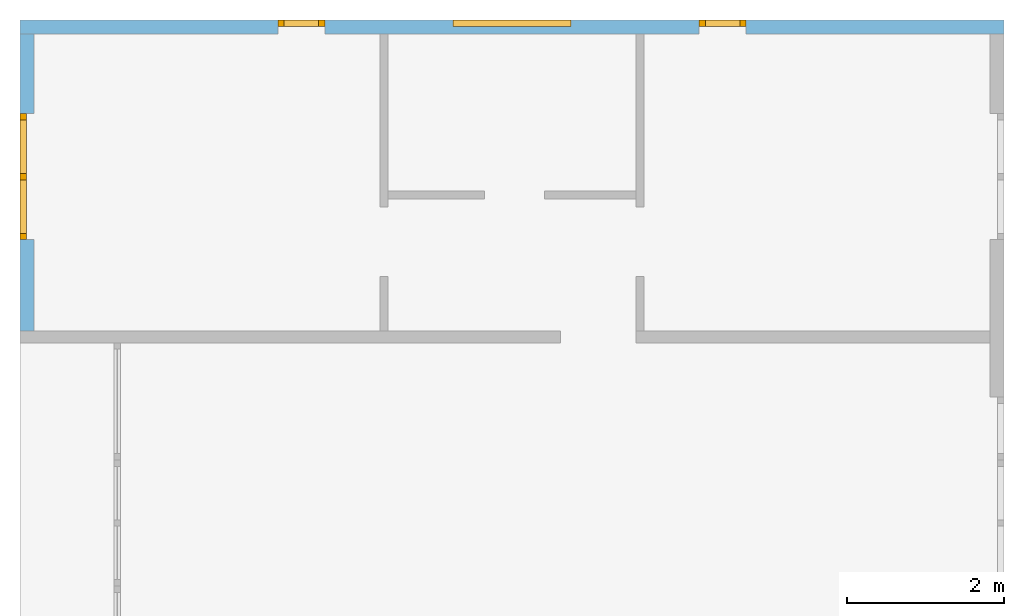
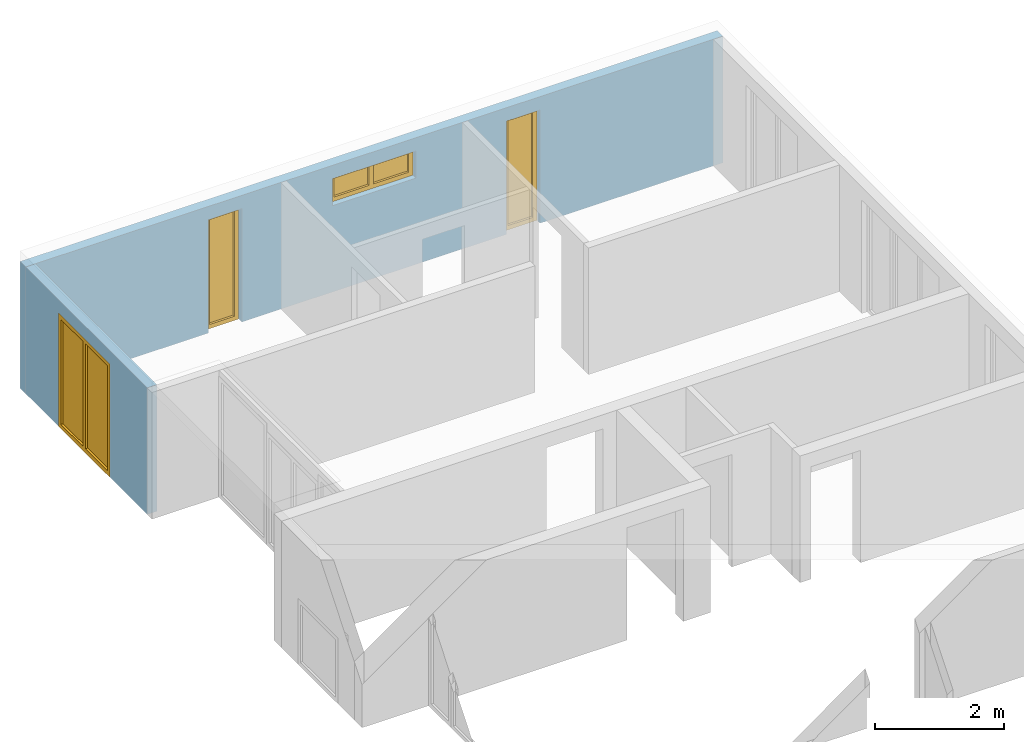
# One storey, part 8 of 8: 4 windows, 4 openings, plus 2 elements that do not belong to this part.
"""IFC2X3 building model written with IfcOpenShell, lengths in millimetres."""

from ifc_helpers import new_model, entity, si_unit, converted_unit, frame, frame_2d, origin, origin_with_axes, place, context, project, spatial, rectangle, extrude, faceted_brep, material, layer, layer_set, layer_usage, element, fill, save


model = new_model("IFC2X3")

# Units and contexts
model_context = context("Model", 3, precision=1e-05, world=origin())
plan_context = context("Plan", 3, precision=1e-05, world=origin())
ifc_project = project(units=[si_unit("LENGTHUNIT", "METRE", prefix="MILLI"), converted_unit("PLANEANGLEUNIT", "DEGREE", entity("IfcPlaneAngleMeasure", 0.0174532925199433), si_unit("PLANEANGLEUNIT", "RADIAN"), dimensions=[0, 0, 0, 0, 0, 0, 0]), si_unit("AREAUNIT", "SQUARE_METRE"), si_unit("VOLUMEUNIT", "CUBIC_METRE")], contexts=[model_context, plan_context])

# Building, storey
building_placement = place(None, origin())
building = spatial("IfcBuilding", under=ifc_project, at=building_placement, CompositionType="ELEMENT")
storey_placement = place(building_placement, frame((0.0, 0.0, 2900.0), z_axis=(0.0, 0.0, 1.0), x_axis=(1.0, 0.0, 0.0)))
storey = spatial("IfcBuildingStorey", under=building, at=storey_placement, Name="OG", CompositionType="ELEMENT", Elevation=2900.0)

# Wall, openings, windows
ifc_material_1 = material(Name="B25")
ifc_layer_1 = layer(ifc_material_1, 175.0)
ifc_layer_set_1 = layer_set([ifc_layer_1])
ifc_layer_usage_1 = layer_usage(ifc_layer_set_1, "AXIS2", "POSITIVE", 0.0)
wall_1_placement = place(storey_placement, frame((33688.3517822139, 9808.4375, 0.0), z_axis=(0.0, 0.0, 1.0), x_axis=(-1.0, 0.0, 0.0)))
wall_1 = element("IfcWallStandardCase", 1, at=wall_1_placement, inside=storey, material=ifc_layer_usage_1, context=model_context, shape_type="SweptSolid", body=[
    extrude(rectangle(XDim=12500.0, YDim=175.0, at=frame_2d((6250.0, 87.5), x_axis=(1.0, 0.0))), origin_with_axes(), (0.0, 0.0, 1.0), 2400.0),
])
opening_1_placement = place(wall_1_placement, frame((3274.9999999553, 0.0, 0.0), z_axis=(0.0, 1.0, 0.0), x_axis=(0.0, 0.0, 1.0)))
opening_1 = element("IfcOpeningElement", 2, at=opening_1_placement, cuts=wall_1, ObjectType="Opening", context=model_context, shape_type="SweptSolid", body=[
    extrude(rectangle(XDim=2150.0, YDim=600.0, at=frame_2d((1075.0, 300.0), x_axis=(1.0, 0.0))), origin_with_axes(), (0.0, 0.0, 1.0), 175.0),
])
opening_2_placement = place(wall_1_placement, frame((5500.00000001148, 0.0, 1635.0), z_axis=(0.0, 1.0, 0.0), x_axis=(0.0, 0.0, 1.0)))
opening_2 = element("IfcOpeningElement", 3, at=opening_2_placement, cuts=wall_1, ObjectType="Opening", context=model_context, shape_type="SweptSolid", body=[
    extrude(rectangle(XDim=515.0, YDim=1500.0, at=frame_2d((257.5, 750.0), x_axis=(1.0, 0.0))), origin_with_axes(), (0.0, 0.0, 1.0), 175.0),
])
opening_3_placement = place(wall_1_placement, frame((8625.0000000447, 0.0, 0.0), z_axis=(0.0, 1.0, 0.0), x_axis=(0.0, 0.0, 1.0)))
opening_3 = element("IfcOpeningElement", 4, at=opening_3_placement, cuts=wall_1, ObjectType="Opening", context=model_context, shape_type="SweptSolid", body=[
    extrude(rectangle(XDim=2150.0, YDim=600.0, at=frame_2d((1075.0, 300.0), x_axis=(1.0, 0.0))), origin_with_axes(), (0.0, 0.0, 1.0), 175.0),
])
ifc_material_2 = material()
window_1_placement = place(opening_1_placement, frame((0.0, 0.0, 0.0), z_axis=(1.0, 0.0, 0.0), x_axis=(0.0, 1.0, 0.0)))
window_1 = element("IfcWindow", 5, at=window_1_placement, inside=storey, material=ifc_material_2, Name="m", OverallHeight=2150.0, OverallWidth=600.0, context=model_context, shape_type="Brep", body=[
    faceted_brep([(80.0, 4.28422852749577e-11, 0.0), (0.0, 4.28619362224936e-11, 0.0), (0.0, 4.28619362224936e-11, 2150.0), (80.0, 4.28422852749577e-11, 2150.0), (0.0, 80.0000000000429, 0.0), (80.0, 80.0000000000428, 0.0), (80.0, 80.0000000000428, 2150.0), (0.0, 80.0000000000429, 2150.0), (0.0, 4.28619362224936e-11, 0.0), (80.0, 4.28422852749577e-11, 0.0), (80.0, 80.0000000000428, 0.0), (0.0, 80.0000000000429, 0.0), (0.0, 4.28619362224936e-11, 2150.0), (0.0, 4.28619362224936e-11, 0.0), (0.0, 80.0000000000429, 0.0), (0.0, 80.0000000000429, 2150.0), (80.0, 4.28422852749577e-11, 2150.0), (0.0, 4.28619362224936e-11, 2150.0), (0.0, 80.0000000000429, 2150.0), (80.0, 80.0000000000428, 2150.0), (80.0, 4.28422852749577e-11, 0.0), (80.0, 4.28422852749577e-11, 2150.0), (80.0, 80.0000000000428, 2150.0), (80.0, 80.0000000000428, 0.0)], [[[0, 1, 2, 3]], [[4, 5, 6, 7]], [[8, 9, 10, 11]], [[12, 13, 14, 15]], [[16, 17, 18, 19]], [[20, 21, 22, 23]]], orient=[[False], [False], [False], [False], [False], [False]]),
    faceted_brep([(520.0, 4.27060609098362e-11, 2150.0), (600.0, 4.26865209846028e-11, 2150.0), (600.0, 4.26865209846028e-11, 0.0), (520.0, 4.27060609098362e-11, 0.0), (600.0, 80.0000000000427, 2150.0), (520.0, 80.0000000000427, 2150.0), (520.0, 80.0000000000427, 0.0), (600.0, 80.0000000000427, 0.0), (600.0, 4.26865209846028e-11, 2150.0), (520.0, 4.27060609098362e-11, 2150.0), (520.0, 80.0000000000427, 2150.0), (600.0, 80.0000000000427, 2150.0), (600.0, 4.26865209846028e-11, 0.0), (600.0, 4.26865209846028e-11, 2150.0), (600.0, 80.0000000000427, 2150.0), (600.0, 80.0000000000427, 0.0), (520.0, 4.27060609098362e-11, 0.0), (600.0, 4.26865209846028e-11, 0.0), (600.0, 80.0000000000427, 0.0), (520.0, 80.0000000000427, 0.0), (520.0, 4.27060609098362e-11, 2150.0), (520.0, 4.27060609098362e-11, 0.0), (520.0, 80.0000000000427, 0.0), (520.0, 80.0000000000427, 2150.0)], [[[0, 1, 2, 3]], [[4, 5, 6, 7]], [[8, 9, 10, 11]], [[12, 13, 14, 15]], [[16, 17, 18, 19]], [[20, 21, 22, 23]]], orient=[[False], [False], [False], [False], [False], [False]]),
    faceted_brep([(520.0, 4.2691850055121e-11, 80.0), (520.0, 4.2691850055121e-11, 0.0), (80.0, 4.27996527108121e-11, 0.0), (80.0, 4.27996527108121e-11, 80.0), (520.0, 80.0000000000427, 0.0), (520.0, 80.0000000000427, 80.0), (80.0, 80.0000000000428, 80.0), (80.0, 80.0000000000428, 0.0), (520.0, 4.2691850055121e-11, 0.0), (520.0, 4.2691850055121e-11, 80.0), (520.0, 80.0000000000427, 80.0), (520.0, 80.0000000000427, 0.0), (80.0, 4.27996527108121e-11, 0.0), (520.0, 4.2691850055121e-11, 0.0), (520.0, 80.0000000000427, 0.0), (80.0, 80.0000000000428, 0.0), (80.0, 4.27996527108121e-11, 80.0), (80.0, 4.27996527108121e-11, 0.0), (80.0, 80.0000000000428, 0.0), (80.0, 80.0000000000428, 80.0), (520.0, 4.2691850055121e-11, 80.0), (80.0, 4.27996527108121e-11, 80.0), (80.0, 80.0000000000428, 80.0), (520.0, 80.0000000000427, 80.0)], [[[0, 1, 2, 3]], [[4, 5, 6, 7]], [[8, 9, 10, 11]], [[12, 13, 14, 15]], [[16, 17, 18, 19]], [[20, 21, 22, 23]]], orient=[[False], [False], [False], [False], [False], [False]]),
    faceted_brep([(80.0, 4.27996527108121e-11, 2070.0), (80.0, 4.27996527108121e-11, 2150.0), (520.0, 4.2691850055121e-11, 2150.0), (520.0, 4.2691850055121e-11, 2070.0), (80.0, 80.0000000000428, 2150.0), (80.0, 80.0000000000428, 2070.0), (520.0, 80.0000000000427, 2070.0), (520.0, 80.0000000000427, 2150.0), (80.0, 4.27996527108121e-11, 2150.0), (80.0, 4.27996527108121e-11, 2070.0), (80.0, 80.0000000000428, 2070.0), (80.0, 80.0000000000428, 2150.0), (520.0, 4.2691850055121e-11, 2150.0), (80.0, 4.27996527108121e-11, 2150.0), (80.0, 80.0000000000428, 2150.0), (520.0, 80.0000000000427, 2150.0), (520.0, 4.2691850055121e-11, 2070.0), (520.0, 4.2691850055121e-11, 2150.0), (520.0, 80.0000000000427, 2150.0), (520.0, 80.0000000000427, 2070.0), (80.0, 4.27996527108121e-11, 2070.0), (520.0, 4.2691850055121e-11, 2070.0), (520.0, 80.0000000000427, 2070.0), (80.0, 80.0000000000428, 2070.0)], [[[0, 1, 2, 3]], [[4, 5, 6, 7]], [[8, 9, 10, 11]], [[12, 13, 14, 15]], [[16, 17, 18, 19]], [[20, 21, 22, 23]]], orient=[[False], [False], [False], [False], [False], [False]]),
    faceted_brep([(520.0, 40.0000000000427, 2070.0), (520.0, 40.0000000000427, 80.0), (80.0, 40.0000000000428, 80.0), (80.0, 40.0000000000428, 2070.0), (520.0, 41.0000000000427, 2070.0), (80.0, 41.0000000000428, 2070.0), (80.0, 41.0000000000428, 80.0), (520.0, 41.0000000000427, 80.0), (520.0, 40.0000000000427, 2070.0), (520.0, 41.0000000000427, 2070.0), (520.0, 41.0000000000427, 80.0), (520.0, 40.0000000000427, 80.0), (520.0, 40.0000000000427, 80.0), (520.0, 41.0000000000427, 80.0), (80.0, 41.0000000000428, 80.0), (80.0, 40.0000000000428, 80.0), (80.0, 40.0000000000428, 80.0), (80.0, 41.0000000000428, 80.0), (80.0, 41.0000000000428, 2070.0), (80.0, 40.0000000000428, 2070.0), (80.0, 40.0000000000428, 2070.0), (80.0, 41.0000000000428, 2070.0), (520.0, 41.0000000000427, 2070.0), (520.0, 40.0000000000427, 2070.0)], [[[0, 1, 2, 3]], [[4, 5, 6, 7]], [[8, 9, 10, 11]], [[12, 13, 14, 15]], [[16, 17, 18, 19]], [[20, 21, 22, 23]]], orient=[[False], [False], [False], [False], [False], [False]]),
])
fill(opening_1, window_1)
ifc_material_3 = material()
window_2_placement = place(opening_2_placement, frame((0.0, 0.0, 0.0), z_axis=(1.0, 0.0, 0.0), x_axis=(0.0, 1.0, 0.0)))
window_2 = element("IfcWindow", 6, at=window_2_placement, inside=storey, material=ifc_material_3, Name="m", OverallHeight=515.0, OverallWidth=1500.0, context=model_context, shape_type="Brep", body=[
    faceted_brep([(1420.0, 4.23280299699513e-11, 0.0), (1420.0, 4.23280299699513e-11, 515.0), (1500.0, 4.23084900447179e-11, 515.0), (1500.0, 4.23084900447179e-11, 0.0), (1500.0, 80.0000000000423, 0.0), (1500.0, 80.0000000000423, 515.0), (1420.0, 80.0000000000423, 515.0), (1420.0, 80.0000000000423, 0.0), (1500.0, 4.23084900447179e-11, 0.0), (1500.0, 80.0000000000423, 0.0), (1420.0, 80.0000000000423, 0.0), (1420.0, 4.23280299699513e-11, 0.0), (1500.0, 4.23084900447179e-11, 515.0), (1500.0, 80.0000000000423, 515.0), (1500.0, 80.0000000000423, 0.0), (1500.0, 4.23084900447179e-11, 0.0), (1420.0, 4.23280299699513e-11, 515.0), (1420.0, 80.0000000000423, 515.0), (1500.0, 80.0000000000423, 515.0), (1500.0, 4.23084900447179e-11, 515.0), (1420.0, 4.23280299699513e-11, 0.0), (1420.0, 80.0000000000423, 0.0), (1420.0, 80.0000000000423, 515.0), (1420.0, 4.23280299699513e-11, 515.0)], [[[0, 1, 2, 3]], [[4, 5, 6, 7]], [[8, 9, 10, 11]], [[12, 13, 14, 15]], [[16, 17, 18, 19]], [[20, 21, 22, 23]]], orient=[[False], [False], [False], [False], [False], [False]]),
    faceted_brep([(80.0, 4.26669810593694e-11, 515.0), (80.0, 4.26669810593694e-11, 0.0), (-1.46952762455441e-16, 4.26865209846028e-11, 0.0), (-1.46952762455441e-16, 4.26865209846028e-11, 515.0), (1.94467488987026e-14, 80.0000000000427, 515.0), (1.94467488987026e-14, 80.0000000000427, 0.0), (80.0, 80.0000000000427, 0.0), (80.0, 80.0000000000427, 515.0), (-1.46952762455441e-16, 4.26865209846028e-11, 515.0), (1.94467488987026e-14, 80.0000000000427, 515.0), (80.0, 80.0000000000427, 515.0), (80.0, 4.26669810593694e-11, 515.0), (-1.46952762455441e-16, 4.26865209846028e-11, 0.0), (1.94467488987026e-14, 80.0000000000427, 0.0), (1.94467488987026e-14, 80.0000000000427, 515.0), (-1.46952762455441e-16, 4.26865209846028e-11, 515.0), (80.0, 4.26669810593694e-11, 0.0), (80.0, 80.0000000000427, 0.0), (1.94467488987026e-14, 80.0000000000427, 0.0), (-1.46952762455441e-16, 4.26865209846028e-11, 0.0), (80.0, 4.26669810593694e-11, 515.0), (80.0, 80.0000000000427, 515.0), (80.0, 80.0000000000427, 0.0), (80.0, 4.26669810593694e-11, 0.0)], [[[0, 1, 2, 3]], [[4, 5, 6, 7]], [[8, 9, 10, 11]], [[12, 13, 14, 15]], [[16, 17, 18, 19]], [[20, 21, 22, 23]]], orient=[[False], [False], [False], [False], [False], [False]]),
    faceted_brep([(1420.0, 4.23706625340969e-11, 435.0), (80.0, 4.26989554824786e-11, 435.0), (80.0, 4.26989554824786e-11, 515.0), (1420.0, 4.23706625340969e-11, 515.0), (1420.0, 80.0000000000424, 515.0), (80.0, 80.0000000000427, 515.0), (80.0, 80.0000000000427, 435.0), (1420.0, 80.0000000000424, 435.0), (1420.0, 4.23706625340969e-11, 515.0), (1420.0, 80.0000000000424, 515.0), (1420.0, 80.0000000000424, 435.0), (1420.0, 4.23706625340969e-11, 435.0), (80.0, 4.26989554824786e-11, 515.0), (80.0, 80.0000000000427, 515.0), (1420.0, 80.0000000000424, 515.0), (1420.0, 4.23706625340969e-11, 515.0), (80.0, 4.26989554824786e-11, 435.0), (80.0, 80.0000000000427, 435.0), (80.0, 80.0000000000427, 515.0), (80.0, 4.26989554824786e-11, 515.0), (1420.0, 4.23706625340969e-11, 435.0), (1420.0, 80.0000000000424, 435.0), (80.0, 80.0000000000427, 435.0), (80.0, 4.26989554824786e-11, 435.0)], [[[0, 1, 2, 3]], [[4, 5, 6, 7]], [[8, 9, 10, 11]], [[12, 13, 14, 15]], [[16, 17, 18, 19]], [[20, 21, 22, 23]]], orient=[[False], [False], [False], [False], [False], [False]]),
    faceted_brep([(80.0, 4.26989554824786e-11, 80.0), (1420.0, 4.23706625340969e-11, 80.0), (1420.0, 4.23706625340969e-11, 0.0), (80.0, 4.26989554824786e-11, 0.0), (80.0, 80.0000000000427, 0.0), (1420.0, 80.0000000000424, 0.0), (1420.0, 80.0000000000424, 80.0), (80.0, 80.0000000000427, 80.0), (80.0, 4.26989554824786e-11, 0.0), (80.0, 80.0000000000427, 0.0), (80.0, 80.0000000000427, 80.0), (80.0, 4.26989554824786e-11, 80.0), (1420.0, 4.23706625340969e-11, 0.0), (1420.0, 80.0000000000424, 0.0), (80.0, 80.0000000000427, 0.0), (80.0, 4.26989554824786e-11, 0.0), (1420.0, 4.23706625340969e-11, 80.0), (1420.0, 80.0000000000424, 80.0), (1420.0, 80.0000000000424, 0.0), (1420.0, 4.23706625340969e-11, 0.0), (80.0, 4.26989554824786e-11, 80.0), (80.0, 80.0000000000427, 80.0), (1420.0, 80.0000000000424, 80.0), (1420.0, 4.23706625340969e-11, 80.0)], [[[0, 1, 2, 3]], [[4, 5, 6, 7]], [[8, 9, 10, 11]], [[12, 13, 14, 15]], [[16, 17, 18, 19]], [[20, 21, 22, 23]]], orient=[[False], [False], [False], [False], [False], [False]]),
    faceted_brep([(710.0, 4.25126600589465e-11, 80.0), (710.0, 4.25126600589465e-11, 435.0), (790.0, 4.24930091114106e-11, 435.0), (790.0, 4.24930091114106e-11, 80.0), (790.0, 80.0000000000425, 80.0), (790.0, 80.0000000000425, 435.0), (710.0, 80.0000000000425, 435.0), (710.0, 80.0000000000425, 80.0), (790.0, 4.24930091114106e-11, 80.0), (790.0, 80.0000000000425, 80.0), (710.0, 80.0000000000425, 80.0), (710.0, 4.25126600589465e-11, 80.0), (790.0, 4.24930091114106e-11, 435.0), (790.0, 80.0000000000425, 435.0), (790.0, 80.0000000000425, 80.0), (790.0, 4.24930091114106e-11, 80.0), (710.0, 4.25126600589465e-11, 435.0), (710.0, 80.0000000000425, 435.0), (790.0, 80.0000000000425, 435.0), (790.0, 4.24930091114106e-11, 435.0), (710.0, 4.25126600589465e-11, 80.0), (710.0, 80.0000000000425, 80.0), (710.0, 80.0000000000425, 435.0), (710.0, 4.25126600589465e-11, 435.0)], [[[0, 1, 2, 3]], [[4, 5, 6, 7]], [[8, 9, 10, 11]], [[12, 13, 14, 15]], [[16, 17, 18, 19]], [[20, 21, 22, 23]]], orient=[[False], [False], [False], [False], [False], [False]]),
    faceted_brep([(80.0, 40.0000000000427, 435.0), (710.0, 40.0000000000425, 435.0), (710.0, 40.0000000000425, 80.0), (80.0, 40.0000000000427, 80.0), (80.0, 41.0000000000427, 435.0), (80.0, 41.0000000000427, 80.0), (710.0, 41.0000000000425, 80.0), (710.0, 41.0000000000425, 435.0), (80.0, 40.0000000000427, 435.0), (80.0, 41.0000000000427, 435.0), (710.0, 41.0000000000425, 435.0), (710.0, 40.0000000000425, 435.0), (710.0, 40.0000000000425, 435.0), (710.0, 41.0000000000425, 435.0), (710.0, 41.0000000000425, 80.0), (710.0, 40.0000000000425, 80.0), (710.0, 40.0000000000425, 80.0), (710.0, 41.0000000000425, 80.0), (80.0, 41.0000000000427, 80.0), (80.0, 40.0000000000427, 80.0), (80.0, 40.0000000000427, 80.0), (80.0, 41.0000000000427, 80.0), (80.0, 41.0000000000427, 435.0), (80.0, 40.0000000000427, 435.0)], [[[0, 1, 2, 3]], [[4, 5, 6, 7]], [[8, 9, 10, 11]], [[12, 13, 14, 15]], [[16, 17, 18, 19]], [[20, 21, 22, 23]]], orient=[[False], [False], [False], [False], [False], [False]]),
    faceted_brep([(1420.0, 40.0000000000424, 80.0), (790.0, 40.0000000000425, 80.0), (790.0, 40.0000000000425, 435.0), (1420.0, 40.0000000000424, 435.0), (1420.0, 41.0000000000424, 80.0), (1420.0, 41.0000000000424, 435.0), (790.0, 41.0000000000425, 435.0), (790.0, 41.0000000000425, 80.0), (1420.0, 40.0000000000424, 80.0), (1420.0, 41.0000000000424, 80.0), (790.0, 41.0000000000425, 80.0), (790.0, 40.0000000000425, 80.0), (790.0, 40.0000000000425, 80.0), (790.0, 41.0000000000425, 80.0), (790.0, 41.0000000000425, 435.0), (790.0, 40.0000000000425, 435.0), (790.0, 40.0000000000425, 435.0), (790.0, 41.0000000000425, 435.0), (1420.0, 41.0000000000424, 435.0), (1420.0, 40.0000000000424, 435.0), (1420.0, 40.0000000000424, 435.0), (1420.0, 41.0000000000424, 435.0), (1420.0, 41.0000000000424, 80.0), (1420.0, 40.0000000000424, 80.0)], [[[0, 1, 2, 3]], [[4, 5, 6, 7]], [[8, 9, 10, 11]], [[12, 13, 14, 15]], [[16, 17, 18, 19]], [[20, 21, 22, 23]]], orient=[[False], [False], [False], [False], [False], [False]]),
])
fill(opening_2, window_2)
ifc_material_4 = material()
window_3_placement = place(opening_3_placement, frame((0.0, 0.0, 0.0), z_axis=(1.0, 0.0, 0.0), x_axis=(0.0, 1.0, 0.0)))
window_3 = element("IfcWindow", 7, at=window_3_placement, inside=storey, material=ifc_material_4, Name="m", OverallHeight=2150.0, OverallWidth=600.0, context=model_context, shape_type="Brep", body=[
    faceted_brep([(80.0, 4.28422852749577e-11, 0.0), (0.0, 4.28619362224936e-11, 0.0), (0.0, 4.28619362224936e-11, 2150.0), (80.0, 4.28422852749577e-11, 2150.0), (0.0, 80.0000000000429, 0.0), (80.0, 80.0000000000428, 0.0), (80.0, 80.0000000000428, 2150.0), (0.0, 80.0000000000429, 2150.0), (0.0, 4.28619362224936e-11, 0.0), (80.0, 4.28422852749577e-11, 0.0), (80.0, 80.0000000000428, 0.0), (0.0, 80.0000000000429, 0.0), (0.0, 4.28619362224936e-11, 2150.0), (0.0, 4.28619362224936e-11, 0.0), (0.0, 80.0000000000429, 0.0), (0.0, 80.0000000000429, 2150.0), (80.0, 4.28422852749577e-11, 2150.0), (0.0, 4.28619362224936e-11, 2150.0), (0.0, 80.0000000000429, 2150.0), (80.0, 80.0000000000428, 2150.0), (80.0, 4.28422852749577e-11, 0.0), (80.0, 4.28422852749577e-11, 2150.0), (80.0, 80.0000000000428, 2150.0), (80.0, 80.0000000000428, 0.0)], [[[0, 1, 2, 3]], [[4, 5, 6, 7]], [[8, 9, 10, 11]], [[12, 13, 14, 15]], [[16, 17, 18, 19]], [[20, 21, 22, 23]]], orient=[[False], [False], [False], [False], [False], [False]]),
    faceted_brep([(520.0, 4.27060609098362e-11, 2150.0), (600.0, 4.26865209846028e-11, 2150.0), (600.0, 4.26865209846028e-11, 0.0), (520.0, 4.27060609098362e-11, 0.0), (600.0, 80.0000000000427, 2150.0), (520.0, 80.0000000000427, 2150.0), (520.0, 80.0000000000427, 0.0), (600.0, 80.0000000000427, 0.0), (600.0, 4.26865209846028e-11, 2150.0), (520.0, 4.27060609098362e-11, 2150.0), (520.0, 80.0000000000427, 2150.0), (600.0, 80.0000000000427, 2150.0), (600.0, 4.26865209846028e-11, 0.0), (600.0, 4.26865209846028e-11, 2150.0), (600.0, 80.0000000000427, 2150.0), (600.0, 80.0000000000427, 0.0), (520.0, 4.27060609098362e-11, 0.0), (600.0, 4.26865209846028e-11, 0.0), (600.0, 80.0000000000427, 0.0), (520.0, 80.0000000000427, 0.0), (520.0, 4.27060609098362e-11, 2150.0), (520.0, 4.27060609098362e-11, 0.0), (520.0, 80.0000000000427, 0.0), (520.0, 80.0000000000427, 2150.0)], [[[0, 1, 2, 3]], [[4, 5, 6, 7]], [[8, 9, 10, 11]], [[12, 13, 14, 15]], [[16, 17, 18, 19]], [[20, 21, 22, 23]]], orient=[[False], [False], [False], [False], [False], [False]]),
    faceted_brep([(520.0, 4.2691850055121e-11, 80.0), (520.0, 4.2691850055121e-11, 0.0), (80.0, 4.27996527108121e-11, 0.0), (80.0, 4.27996527108121e-11, 80.0), (520.0, 80.0000000000427, 0.0), (520.0, 80.0000000000427, 80.0), (80.0, 80.0000000000428, 80.0), (80.0, 80.0000000000428, 0.0), (520.0, 4.2691850055121e-11, 0.0), (520.0, 4.2691850055121e-11, 80.0), (520.0, 80.0000000000427, 80.0), (520.0, 80.0000000000427, 0.0), (80.0, 4.27996527108121e-11, 0.0), (520.0, 4.2691850055121e-11, 0.0), (520.0, 80.0000000000427, 0.0), (80.0, 80.0000000000428, 0.0), (80.0, 4.27996527108121e-11, 80.0), (80.0, 4.27996527108121e-11, 0.0), (80.0, 80.0000000000428, 0.0), (80.0, 80.0000000000428, 80.0), (520.0, 4.2691850055121e-11, 80.0), (80.0, 4.27996527108121e-11, 80.0), (80.0, 80.0000000000428, 80.0), (520.0, 80.0000000000427, 80.0)], [[[0, 1, 2, 3]], [[4, 5, 6, 7]], [[8, 9, 10, 11]], [[12, 13, 14, 15]], [[16, 17, 18, 19]], [[20, 21, 22, 23]]], orient=[[False], [False], [False], [False], [False], [False]]),
    faceted_brep([(80.0, 4.27996527108121e-11, 2070.0), (80.0, 4.27996527108121e-11, 2150.0), (520.0, 4.2691850055121e-11, 2150.0), (520.0, 4.2691850055121e-11, 2070.0), (80.0, 80.0000000000428, 2150.0), (80.0, 80.0000000000428, 2070.0), (520.0, 80.0000000000427, 2070.0), (520.0, 80.0000000000427, 2150.0), (80.0, 4.27996527108121e-11, 2150.0), (80.0, 4.27996527108121e-11, 2070.0), (80.0, 80.0000000000428, 2070.0), (80.0, 80.0000000000428, 2150.0), (520.0, 4.2691850055121e-11, 2150.0), (80.0, 4.27996527108121e-11, 2150.0), (80.0, 80.0000000000428, 2150.0), (520.0, 80.0000000000427, 2150.0), (520.0, 4.2691850055121e-11, 2070.0), (520.0, 4.2691850055121e-11, 2150.0), (520.0, 80.0000000000427, 2150.0), (520.0, 80.0000000000427, 2070.0), (80.0, 4.27996527108121e-11, 2070.0), (520.0, 4.2691850055121e-11, 2070.0), (520.0, 80.0000000000427, 2070.0), (80.0, 80.0000000000428, 2070.0)], [[[0, 1, 2, 3]], [[4, 5, 6, 7]], [[8, 9, 10, 11]], [[12, 13, 14, 15]], [[16, 17, 18, 19]], [[20, 21, 22, 23]]], orient=[[False], [False], [False], [False], [False], [False]]),
    faceted_brep([(520.0, 40.0000000000427, 2070.0), (520.0, 40.0000000000427, 80.0), (80.0, 40.0000000000428, 80.0), (80.0, 40.0000000000428, 2070.0), (520.0, 41.0000000000427, 2070.0), (80.0, 41.0000000000428, 2070.0), (80.0, 41.0000000000428, 80.0), (520.0, 41.0000000000427, 80.0), (520.0, 40.0000000000427, 2070.0), (520.0, 41.0000000000427, 2070.0), (520.0, 41.0000000000427, 80.0), (520.0, 40.0000000000427, 80.0), (520.0, 40.0000000000427, 80.0), (520.0, 41.0000000000427, 80.0), (80.0, 41.0000000000428, 80.0), (80.0, 40.0000000000428, 80.0), (80.0, 40.0000000000428, 80.0), (80.0, 41.0000000000428, 80.0), (80.0, 41.0000000000428, 2070.0), (80.0, 40.0000000000428, 2070.0), (80.0, 40.0000000000428, 2070.0), (80.0, 41.0000000000428, 2070.0), (520.0, 41.0000000000427, 2070.0), (520.0, 40.0000000000427, 2070.0)], [[[0, 1, 2, 3]], [[4, 5, 6, 7]], [[8, 9, 10, 11]], [[12, 13, 14, 15]], [[16, 17, 18, 19]], [[20, 21, 22, 23]]], orient=[[False], [False], [False], [False], [False], [False]]),
])
fill(opening_3, window_3)

# Wall, opening, window
ifc_material_5 = material(Name="B25")
ifc_layer_2 = layer(ifc_material_5, 175.0)
ifc_layer_set_2 = layer_set([ifc_layer_2])
ifc_layer_usage_2 = layer_usage(ifc_layer_set_2, "AXIS2", "POSITIVE", 0.0)
wall_2_placement = place(storey_placement, frame((21188.3517822139, 9633.4375, 0.0), z_axis=(0.0, 0.0, 1.0), x_axis=(0.0, -1.0, 0.0)))
wall_2 = element("IfcWallStandardCase", 8, at=wall_2_placement, inside=storey, material=ifc_layer_usage_2, context=model_context, shape_type="SweptSolid", body=[
    extrude(rectangle(XDim=3775.0, YDim=175.0, at=frame_2d((1887.5, 87.5), x_axis=(1.0, 0.0))), origin_with_axes(), (0.0, 0.0, 1.0), 2400.0),
])
opening_4_placement = place(wall_2_placement, frame((1015.0, 0.0, 0.0), z_axis=(0.0, 1.0, 0.0), x_axis=(0.0, 0.0, 1.0)))
opening_4 = element("IfcOpeningElement", 9, at=opening_4_placement, cuts=wall_2, ObjectType="Opening", context=model_context, shape_type="SweptSolid", body=[
    extrude(rectangle(XDim=2150.0, YDim=1600.0, at=frame_2d((1075.0, 800.0), x_axis=(1.0, 0.0))), origin_with_axes(), (0.0, 0.0, 1.0), 175.0),
])
ifc_material_6 = material()
window_4_placement = place(opening_4_placement, frame((0.0, 0.0, 0.0), z_axis=(1.0, 0.0, 0.0), x_axis=(0.0, 1.0, 0.0)))
window_4 = element("IfcWindow", 10, at=window_4_placement, inside=storey, material=ifc_material_6, Name="m", OverallHeight=2150.0, OverallWidth=1600.0, context=model_context, shape_type="Brep", body=[
    faceted_brep([(80.0000000000009, 4.37465619285149e-11, 0.0), (9.09494701772928e-13, 4.37514469098232e-11, 0.0), (9.09494701772928e-13, 4.37514469098232e-11, 2150.0), (80.0000000000009, 4.37465619285149e-11, 2150.0), (9.09494701772928e-13, 80.0000000000437, 0.0), (80.0000000000009, 80.0000000000437, 0.0), (80.0000000000009, 80.0000000000437, 2150.0), (9.09494701772928e-13, 80.0000000000437, 2150.0), (9.09494701772928e-13, 4.37514469098232e-11, 0.0), (80.0000000000009, 4.37465619285149e-11, 0.0), (80.0000000000009, 80.0000000000437, 0.0), (9.09494701772928e-13, 80.0000000000437, 0.0), (9.09494701772928e-13, 4.37514469098232e-11, 2150.0), (9.09494701772928e-13, 4.37514469098232e-11, 0.0), (9.09494701772928e-13, 80.0000000000437, 0.0), (9.09494701772928e-13, 80.0000000000437, 2150.0), (80.0000000000009, 4.37465619285149e-11, 2150.0), (9.09494701772928e-13, 4.37514469098232e-11, 2150.0), (9.09494701772928e-13, 80.0000000000437, 2150.0), (80.0000000000009, 80.0000000000437, 2150.0), (80.0000000000009, 4.37465619285149e-11, 0.0), (80.0000000000009, 4.37465619285149e-11, 2150.0), (80.0000000000009, 80.0000000000437, 2150.0), (80.0000000000009, 80.0000000000437, 0.0)], [[[0, 1, 2, 3]], [[4, 5, 6, 7]], [[8, 9, 10, 11]], [[12, 13, 14, 15]], [[16, 17, 18, 19]], [[20, 21, 22, 23]]], orient=[[False], [False], [False], [False], [False], [False]]),
    faceted_brep([(1520.0, 4.36406466519657e-11, 2150.0), (1600.0, 4.36357616706573e-11, 2150.0), (1600.0, 4.36357616706573e-11, 0.0), (1520.0, 4.36406466519657e-11, 0.0), (1600.0, 80.0000000000436, 2150.0), (1520.0, 80.0000000000436, 2150.0), (1520.0, 80.0000000000436, 0.0), (1600.0, 80.0000000000436, 0.0), (1600.0, 4.36357616706573e-11, 2150.0), (1520.0, 4.36406466519657e-11, 2150.0), (1520.0, 80.0000000000436, 2150.0), (1600.0, 80.0000000000436, 2150.0), (1600.0, 4.36357616706573e-11, 0.0), (1600.0, 4.36357616706573e-11, 2150.0), (1600.0, 80.0000000000436, 2150.0), (1600.0, 80.0000000000436, 0.0), (1520.0, 4.36406466519657e-11, 0.0), (1600.0, 4.36357616706573e-11, 0.0), (1600.0, 80.0000000000436, 0.0), (1520.0, 80.0000000000436, 0.0), (1520.0, 4.36406466519657e-11, 2150.0), (1520.0, 4.36406466519657e-11, 0.0), (1520.0, 80.0000000000436, 0.0), (1520.0, 80.0000000000436, 2150.0)], [[[0, 1, 2, 3]], [[4, 5, 6, 7]], [[8, 9, 10, 11]], [[12, 13, 14, 15]], [[16, 17, 18, 19]], [[20, 21, 22, 23]]], orient=[[False], [False], [False], [False], [False], [False]]),
    faceted_brep([(1520.0, 4.36406466519657e-11, 80.0), (1520.0, 4.36406466519657e-11, 0.0), (80.0000000000009, 4.37287983601209e-11, 0.0), (80.0000000000009, 4.37287983601209e-11, 80.0), (1520.0, 80.0000000000436, 0.0), (1520.0, 80.0000000000436, 80.0), (80.0000000000009, 80.0000000000437, 80.0), (80.0000000000009, 80.0000000000437, 0.0), (1520.0, 4.36406466519657e-11, 0.0), (1520.0, 4.36406466519657e-11, 80.0), (1520.0, 80.0000000000436, 80.0), (1520.0, 80.0000000000436, 0.0), (80.0000000000009, 4.37287983601209e-11, 0.0), (1520.0, 4.36406466519657e-11, 0.0), (1520.0, 80.0000000000436, 0.0), (80.0000000000009, 80.0000000000437, 0.0), (80.0000000000009, 4.37287983601209e-11, 80.0), (80.0000000000009, 4.37287983601209e-11, 0.0), (80.0000000000009, 80.0000000000437, 0.0), (80.0000000000009, 80.0000000000437, 80.0), (1520.0, 4.36406466519657e-11, 80.0), (80.0000000000009, 4.37287983601209e-11, 80.0), (80.0000000000009, 80.0000000000437, 80.0), (1520.0, 80.0000000000436, 80.0)], [[[0, 1, 2, 3]], [[4, 5, 6, 7]], [[8, 9, 10, 11]], [[12, 13, 14, 15]], [[16, 17, 18, 19]], [[20, 21, 22, 23]]], orient=[[False], [False], [False], [False], [False], [False]]),
    faceted_brep([(80.0000000000009, 4.37287983601209e-11, 2070.0), (80.0000000000009, 4.37287983601209e-11, 2150.0), (1520.0, 4.36406466519657e-11, 2150.0), (1520.0, 4.36406466519657e-11, 2070.0), (80.0000000000009, 80.0000000000437, 2150.0), (80.0000000000009, 80.0000000000437, 2070.0), (1520.0, 80.0000000000436, 2070.0), (1520.0, 80.0000000000436, 2150.0), (80.0000000000009, 4.37287983601209e-11, 2150.0), (80.0000000000009, 4.37287983601209e-11, 2070.0), (80.0000000000009, 80.0000000000437, 2070.0), (80.0000000000009, 80.0000000000437, 2150.0), (1520.0, 4.36406466519657e-11, 2150.0), (80.0000000000009, 4.37287983601209e-11, 2150.0), (80.0000000000009, 80.0000000000437, 2150.0), (1520.0, 80.0000000000436, 2150.0), (1520.0, 4.36406466519657e-11, 2070.0), (1520.0, 4.36406466519657e-11, 2150.0), (1520.0, 80.0000000000436, 2150.0), (1520.0, 80.0000000000436, 2070.0), (80.0000000000009, 4.37287983601209e-11, 2070.0), (1520.0, 4.36406466519657e-11, 2070.0), (1520.0, 80.0000000000436, 2070.0), (80.0000000000009, 80.0000000000437, 2070.0)], [[[0, 1, 2, 3]], [[4, 5, 6, 7]], [[8, 9, 10, 11]], [[12, 13, 14, 15]], [[16, 17, 18, 19]], [[20, 21, 22, 23]]], orient=[[False], [False], [False], [False], [False], [False]]),
    faceted_brep([(840.0, 4.36822800153891e-11, 80.0), (760.0, 4.36871649966974e-11, 80.0), (760.0, 4.36871649966974e-11, 2070.0), (840.0, 4.36822800153891e-11, 2070.0), (760.0, 80.0000000000437, 80.0), (840.0, 80.0000000000437, 80.0), (840.0, 80.0000000000437, 2070.0), (760.0, 80.0000000000437, 2070.0), (760.0, 4.36871649966974e-11, 80.0), (840.0, 4.36822800153891e-11, 80.0), (840.0, 80.0000000000437, 80.0), (760.0, 80.0000000000437, 80.0), (760.0, 4.36871649966974e-11, 2070.0), (760.0, 4.36871649966974e-11, 80.0), (760.0, 80.0000000000437, 80.0), (760.0, 80.0000000000437, 2070.0), (840.0, 4.36822800153891e-11, 2070.0), (760.0, 4.36871649966974e-11, 2070.0), (760.0, 80.0000000000437, 2070.0), (840.0, 80.0000000000437, 2070.0), (840.0, 4.36822800153891e-11, 80.0), (840.0, 4.36822800153891e-11, 2070.0), (840.0, 80.0000000000437, 2070.0), (840.0, 80.0000000000437, 80.0)], [[[0, 1, 2, 3]], [[4, 5, 6, 7]], [[8, 9, 10, 11]], [[12, 13, 14, 15]], [[16, 17, 18, 19]], [[20, 21, 22, 23]]], orient=[[False], [False], [False], [False], [False], [False]]),
    faceted_brep([(1520.0, 40.0000000000436, 2070.0), (1520.0, 40.0000000000436, 80.0), (840.0, 40.0000000000437, 80.0), (840.0, 40.0000000000437, 2070.0), (1520.0, 41.0000000000436, 2070.0), (840.0, 41.0000000000437, 2070.0), (840.0, 41.0000000000437, 80.0), (1520.0, 41.0000000000436, 80.0), (1520.0, 40.0000000000436, 2070.0), (1520.0, 41.0000000000436, 2070.0), (1520.0, 41.0000000000436, 80.0), (1520.0, 40.0000000000436, 80.0), (1520.0, 40.0000000000436, 80.0), (1520.0, 41.0000000000436, 80.0), (840.0, 41.0000000000437, 80.0), (840.0, 40.0000000000437, 80.0), (840.0, 40.0000000000437, 80.0), (840.0, 41.0000000000437, 80.0), (840.0, 41.0000000000437, 2070.0), (840.0, 40.0000000000437, 2070.0), (840.0, 40.0000000000437, 2070.0), (840.0, 41.0000000000437, 2070.0), (1520.0, 41.0000000000436, 2070.0), (1520.0, 40.0000000000436, 2070.0)], [[[0, 1, 2, 3]], [[4, 5, 6, 7]], [[8, 9, 10, 11]], [[12, 13, 14, 15]], [[16, 17, 18, 19]], [[20, 21, 22, 23]]], orient=[[False], [False], [False], [False], [False], [False]]),
    faceted_brep([(760.0, 40.0000000000437, 2070.0), (760.0, 40.0000000000437, 80.0), (80.0000000000009, 40.0000000000437, 80.0), (80.0000000000009, 40.0000000000437, 2070.0), (760.0, 41.0000000000437, 2070.0), (80.0000000000009, 41.0000000000437, 2070.0), (80.0000000000009, 41.0000000000437, 80.0), (760.0, 41.0000000000437, 80.0), (760.0, 40.0000000000437, 2070.0), (760.0, 41.0000000000437, 2070.0), (760.0, 41.0000000000437, 80.0), (760.0, 40.0000000000437, 80.0), (760.0, 40.0000000000437, 80.0), (760.0, 41.0000000000437, 80.0), (80.0000000000009, 41.0000000000437, 80.0), (80.0000000000009, 40.0000000000437, 80.0), (80.0000000000009, 40.0000000000437, 80.0), (80.0000000000009, 41.0000000000437, 80.0), (80.0000000000009, 41.0000000000437, 2070.0), (80.0000000000009, 40.0000000000437, 2070.0), (80.0000000000009, 40.0000000000437, 2070.0), (80.0000000000009, 41.0000000000437, 2070.0), (760.0, 41.0000000000437, 2070.0), (760.0, 40.0000000000437, 2070.0)], [[[0, 1, 2, 3]], [[4, 5, 6, 7]], [[8, 9, 10, 11]], [[12, 13, 14, 15]], [[16, 17, 18, 19]], [[20, 21, 22, 23]]], orient=[[False], [False], [False], [False], [False], [False]]),
])
fill(opening_4, window_4)

save(model, "model.ifc")
